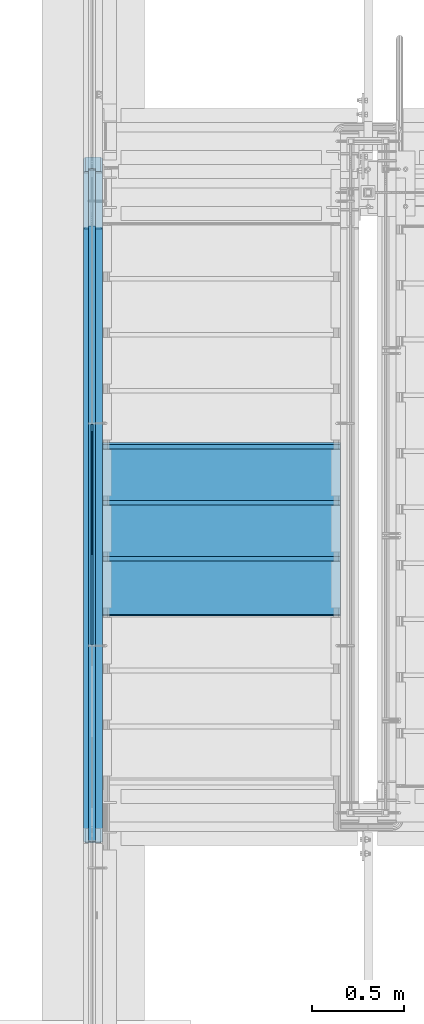
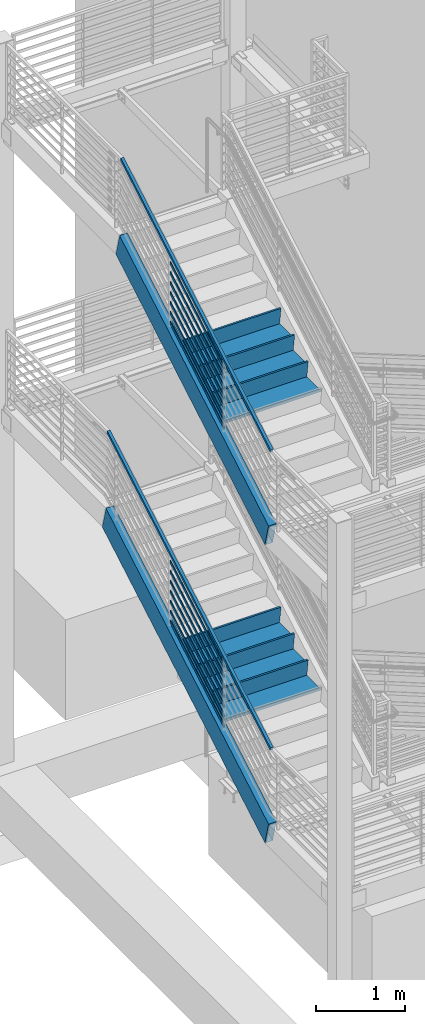
# One storey, part 754 of 1179: 18 members, 6 beams, 4 elements without a shape of their own.
"""IFC2X3 building model written with IfcOpenShell, lengths in millimetres."""

from ifc_helpers import new_model, si_unit, frame, origin_with_axes, place, context, subcontext, project, spatial, faceted_brep, material, type_object, element, aggregate, save


model = new_model("IFC2X3")

# Units and contexts
model_context = context("Model", 3, precision=1e-05, world=origin_with_axes())
body_context = subcontext(model_context, "Body", "Model", "MODEL_VIEW")
ifc_project = project(units=[si_unit("LENGTHUNIT", "METRE", prefix="MILLI"), si_unit("AREAUNIT", "SQUARE_METRE"), si_unit("VOLUMEUNIT", "CUBIC_METRE"), si_unit("MASSUNIT", "GRAM", prefix="KILO"), si_unit("TIMEUNIT", "SECOND"), si_unit("PLANEANGLEUNIT", "RADIAN"), si_unit("SOLIDANGLEUNIT", "STERADIAN"), si_unit("THERMODYNAMICTEMPERATUREUNIT", "DEGREE_CELSIUS"), si_unit("LUMINOUSINTENSITYUNIT", "LUMEN")], contexts=[model_context])

# Site, building, storey
site_placement = place(None, origin_with_axes())
site = spatial("IfcSite", under=ifc_project, at=site_placement, CompositionType="ELEMENT")
building_placement = place(site_placement, origin_with_axes())
building = spatial("IfcBuilding", under=site, at=building_placement, Name="Undefined", CompositionType="ELEMENT")
storey_placement = place(building_placement, origin_with_axes())
storey = spatial("IfcBuildingStorey", under=building, at=storey_placement, Name="Undefined", CompositionType="ELEMENT", Elevation=0.0)

# Assembly, members
assembly_1_placement = place(storey_placement, origin_with_axes())
assembly_1 = element("IfcElementAssembly", 1, at=assembly_1_placement, inside=storey, Name="GUARDRAIL", AssemblyPlace="NOTDEFINED", PredefinedType="RIGID_FRAME")
ifc_material_1 = material(Name="STEEL/A36")
member_type_1 = type_object("IfcMemberType", PredefinedType="NOTDEFINED")
member_1_placement = place(assembly_1_placement, frame((-3257.54999923555, 33867.7987430372, 7639.66614755741), z_axis=(0.0, -0.503871025834967, 0.863778900717086), x_axis=(0.0, -0.863778900717086, -0.503871025834967)))
member_1 = element("IfcMember", 2, at=member_1_placement, type_object=member_type_1, material=ifc_material_1, Name="PLATE", context=body_context, shape_type="Brep", body=[
    faceted_brep([(27.7385637234547, 4.76250000000005, -19.0500000000011), (5.51356370517169, 4.76250000000005, 19.0500000000338), (1396.15685487731, 4.76250000000005, 19.0500000012689), (1418.38185489559, 4.76250000000005, -19.049999998766), (5.51356370517169, -4.76250000000005, 19.0500000000338), (1396.15685487731, -4.76250000000005, 19.0500000012689), (27.7385637234547, -4.76250000000005, -19.0500000000011), (1418.38185489559, -4.76250000000005, -19.049999998766)], [[[0, 1, 2, 3]], [[1, 4, 5, 2]], [[4, 6, 7, 5]], [[6, 0, 3, 7]], [[5, 7, 3, 2]], [[6, 4, 1, 0]]]),
])
member_2_placement = place(assembly_1_placement, frame((-3257.54999923555, 33867.7987430373, 7775.83092631768), z_axis=(0.0, -0.503871025834967, 0.863778900717086), x_axis=(0.0, -0.863778900717086, -0.503871025834967)))
member_2 = element("IfcMember", 3, at=member_2_placement, type_object=member_type_1, material=ifc_material_1, Name="PLATE", context=body_context, shape_type="Brep", body=[
    faceted_brep([(27.7385637234547, 4.76250000000005, -19.0500000000011), (5.51356370517169, 4.76250000000005, 19.0500000000338), (1396.15685487731, 4.76250000000005, 19.0500000012689), (1418.38185489559, 4.76250000000005, -19.049999998766), (5.51356370517169, -4.76250000000005, 19.0500000000338), (1396.15685487731, -4.76250000000005, 19.0500000012689), (27.7385637234547, -4.76250000000005, -19.0500000000011), (1418.38185489559, -4.76250000000005, -19.049999998766)], [[[0, 1, 2, 3]], [[1, 4, 5, 2]], [[4, 6, 7, 5]], [[6, 0, 3, 7]], [[5, 7, 3, 2]], [[6, 4, 1, 0]]]),
])
member_3_placement = place(assembly_1_placement, frame((-3257.54999923555, 33867.7987430373, 7912.01384991899), z_axis=(0.0, -0.503871025834967, 0.863778900717086), x_axis=(0.0, -0.863778900717086, -0.503871025834967)))
member_3 = element("IfcMember", 4, at=member_3_placement, type_object=member_type_1, material=ifc_material_1, Name="PLATE", context=body_context, shape_type="Brep", body=[
    faceted_brep([(27.7385637234547, 4.76250000000005, -19.0500000000011), (5.51356370517169, 4.76250000000005, 19.0500000000338), (1396.15685487731, 4.76250000000005, 19.0500000012689), (1418.38185489559, 4.76250000000005, -19.049999998766), (5.51356370517169, -4.76250000000005, 19.0500000000338), (1396.15685487731, -4.76250000000005, 19.0500000012689), (27.7385637234547, -4.76250000000005, -19.0500000000011), (1418.38185489559, -4.76250000000005, -19.049999998766)], [[[0, 1, 2, 3]], [[1, 4, 5, 2]], [[4, 6, 7, 5]], [[6, 0, 3, 7]], [[5, 7, 3, 2]], [[6, 4, 1, 0]]]),
])
member_4_placement = place(assembly_1_placement, frame((-3257.54999923555, 33867.7987430373, 8048.19677352032), z_axis=(0.0, -0.503871025834967, 0.863778900717086), x_axis=(0.0, -0.863778900717086, -0.503871025834967)))
member_4 = element("IfcMember", 5, at=member_4_placement, type_object=member_type_1, material=ifc_material_1, Name="PLATE", context=body_context, shape_type="Brep", body=[
    faceted_brep([(27.7385637234547, 4.76250000000005, -19.0500000000011), (5.51356370517169, 4.76250000000005, 19.0500000000338), (1396.15685487731, 4.76250000000005, 19.0500000012689), (1418.38185489559, 4.76250000000005, -19.049999998766), (5.51356370517169, -4.76250000000005, 19.0500000000338), (1396.15685487731, -4.76250000000005, 19.0500000012689), (27.7385637234547, -4.76250000000005, -19.0500000000011), (1418.38185489559, -4.76250000000005, -19.049999998766)], [[[0, 1, 2, 3]], [[1, 4, 5, 2]], [[4, 6, 7, 5]], [[6, 0, 3, 7]], [[5, 7, 3, 2]], [[6, 4, 1, 0]]]),
])
member_5_placement = place(assembly_1_placement, frame((-3257.54999923555, 33867.7987430417, 8184.37969712425), z_axis=(0.0, -0.503871025834967, 0.863778900717086), x_axis=(0.0, -0.863778900717086, -0.503871025834967)))
member_5 = element("IfcMember", 6, at=member_5_placement, type_object=member_type_1, material=ifc_material_1, Name="PLATE", context=body_context, shape_type="Brep", body=[
    faceted_brep([(27.7385637234547, 4.76250000000005, -19.0500000000011), (5.51356370517169, 4.76250000000005, 19.0500000000338), (1396.15685487731, 4.76250000000005, 19.0500000012689), (1418.38185489559, 4.76250000000005, -19.049999998766), (5.51356370517169, -4.76250000000005, 19.0500000000338), (1396.15685487731, -4.76250000000005, 19.0500000012689), (27.7385637234547, -4.76250000000005, -19.0500000000011), (1418.38185489559, -4.76250000000005, -19.049999998766)], [[[0, 1, 2, 3]], [[1, 4, 5, 2]], [[4, 6, 7, 5]], [[6, 0, 3, 7]], [[5, 7, 3, 2]], [[6, 4, 1, 0]]]),
])
member_6_placement = place(assembly_1_placement, frame((-3257.54999923555, 33867.7987430361, 8320.56262072233), z_axis=(0.0, -0.503871025834967, 0.863778900717086), x_axis=(0.0, -0.863778900717086, -0.503871025834967)))
member_6 = element("IfcMember", 7, at=member_6_placement, type_object=member_type_1, material=ifc_material_1, Name="PLATE", context=body_context, shape_type="Brep", body=[
    faceted_brep([(27.7385637234547, 4.76250000000005, -19.0500000000011), (5.51356370517169, 4.76250000000005, 19.0500000000338), (1396.15685487731, 4.76250000000005, 19.0500000012689), (1418.38185489559, 4.76250000000005, -19.049999998766), (5.51356370517169, -4.76250000000005, 19.0500000000338), (1396.15685487731, -4.76250000000005, 19.0500000012689), (27.7385637234547, -4.76250000000005, -19.0500000000011), (1418.38185489559, -4.76250000000005, -19.049999998766)], [[[0, 1, 2, 3]], [[1, 4, 5, 2]], [[4, 6, 7, 5]], [[6, 0, 3, 7]], [[5, 7, 3, 2]], [[6, 4, 1, 0]]]),
])
member_7_placement = place(assembly_1_placement, frame((-3257.54999923555, 33867.7987430429, 8456.74554432763), z_axis=(0.0, -0.503871025834967, 0.863778900717086), x_axis=(0.0, -0.863778900717086, -0.503871025834967)))
member_7 = element("IfcMember", 8, at=member_7_placement, type_object=member_type_1, material=ifc_material_1, Name="PLATE", context=body_context, shape_type="Brep", body=[
    faceted_brep([(27.7385637234547, 4.76250000000005, -19.0500000000011), (5.51356370517169, 4.76250000000005, 19.0500000000338), (1396.15685487731, 4.76250000000005, 19.0500000012689), (1418.38185489559, 4.76250000000005, -19.049999998766), (5.51356370517169, -4.76250000000005, 19.0500000000338), (1396.15685487731, -4.76250000000005, 19.0500000012689), (27.7385637234547, -4.76250000000005, -19.0500000000011), (1418.38185489559, -4.76250000000005, -19.049999998766)], [[[0, 1, 2, 3]], [[1, 4, 5, 2]], [[4, 6, 7, 5]], [[6, 0, 3, 7]], [[5, 7, 3, 2]], [[6, 4, 1, 0]]]),
])

assembly_2_placement = place(storey_placement, origin_with_axes())
assembly_2 = element("IfcElementAssembly", 9, at=assembly_2_placement, inside=storey, Name="GUARDRAIL", AssemblyPlace="NOTDEFINED", PredefinedType="RIGID_FRAME")
member_8_placement = place(assembly_2_placement, frame((-3257.54999923555, 33867.745305077, 3556.74864643349), z_axis=(0.0, -0.501065882891537, 0.865409140812671), x_axis=(0.0, -0.86540914081267, -0.501065882891538)))
member_8 = element("IfcMember", 10, at=member_8_placement, type_object=member_type_1, material=ifc_material_1, Name="PLATE", context=body_context, shape_type="Brep", body=[
    faceted_brep([(27.5628128089447, 4.76250000000005, -19.0499999999756), (5.50317738577724, 4.76250000000005, 19.0499999999902), (1393.52680304928, 4.76249999999982, 19.0499999980784), (1415.58643847238, 4.76249999999982, -19.0500000019292), (5.50317738577724, -4.76250000000005, 19.0499999999902), (1393.52680304928, -4.76250000000027, 19.0499999980784), (27.5628128089447, -4.76250000000005, -19.0499999999756), (1415.58643847238, -4.76250000000027, -19.0500000019292)], [[[0, 1, 2, 3]], [[1, 4, 5, 2]], [[4, 6, 7, 5]], [[6, 0, 3, 7]], [[5, 7, 3, 2]], [[6, 4, 1, 0]]]),
])
member_9_placement = place(assembly_2_placement, frame((-3257.54999923555, 33867.745305077, 3692.849065398), z_axis=(0.0, -0.501065882891537, 0.865409140812671), x_axis=(0.0, -0.86540914081267, -0.501065882891538)))
member_9 = element("IfcMember", 11, at=member_9_placement, type_object=member_type_1, material=ifc_material_1, Name="PLATE", context=body_context, shape_type="Brep", body=[
    faceted_brep([(27.5628128089447, 4.76250000000005, -19.0499999999756), (5.50317738577724, 4.76250000000005, 19.0499999999902), (1393.52680304928, 4.76249999999982, 19.0499999980784), (1415.58643847238, 4.76249999999982, -19.0500000019292), (5.50317738577724, -4.76250000000005, 19.0499999999902), (1393.52680304928, -4.76250000000027, 19.0499999980784), (27.5628128089447, -4.76250000000005, -19.0499999999756), (1415.58643847238, -4.76250000000027, -19.0500000019292)], [[[0, 1, 2, 3]], [[1, 4, 5, 2]], [[4, 6, 7, 5]], [[6, 0, 3, 7]], [[5, 7, 3, 2]], [[6, 4, 1, 0]]]),
])
member_10_placement = place(assembly_2_placement, frame((-3257.54999923555, 33867.745305077, 3828.94948436251), z_axis=(0.0, -0.501065882891537, 0.865409140812671), x_axis=(0.0, -0.86540914081267, -0.501065882891538)))
member_10 = element("IfcMember", 12, at=member_10_placement, type_object=member_type_1, material=ifc_material_1, Name="PLATE", context=body_context, shape_type="Brep", body=[
    faceted_brep([(27.5628128089447, 4.76250000000005, -19.0499999999756), (5.50317738577724, 4.76250000000005, 19.0499999999902), (1393.52680304928, 4.76249999999982, 19.0499999980784), (1415.58643847238, 4.76249999999982, -19.0500000019292), (5.50317738577724, -4.76250000000005, 19.0499999999902), (1393.52680304928, -4.76250000000027, 19.0499999980784), (27.5628128089447, -4.76250000000005, -19.0499999999756), (1415.58643847238, -4.76250000000027, -19.0500000019292)], [[[0, 1, 2, 3]], [[1, 4, 5, 2]], [[4, 6, 7, 5]], [[6, 0, 3, 7]], [[5, 7, 3, 2]], [[6, 4, 1, 0]]]),
])
member_11_placement = place(assembly_2_placement, frame((-3257.54999923555, 33867.745305077, 3965.04990332702), z_axis=(0.0, -0.501065882891537, 0.865409140812671), x_axis=(0.0, -0.86540914081267, -0.501065882891538)))
member_11 = element("IfcMember", 13, at=member_11_placement, type_object=member_type_1, material=ifc_material_1, Name="PLATE", context=body_context, shape_type="Brep", body=[
    faceted_brep([(27.5628128089447, 4.76250000000005, -19.0499999999756), (5.50317738577724, 4.76250000000005, 19.0499999999902), (1393.52680304928, 4.76249999999982, 19.0499999980784), (1415.58643847238, 4.76249999999982, -19.0500000019292), (5.50317738577724, -4.76250000000005, 19.0499999999902), (1393.52680304928, -4.76250000000027, 19.0499999980784), (27.5628128089447, -4.76250000000005, -19.0499999999756), (1415.58643847238, -4.76250000000027, -19.0500000019292)], [[[0, 1, 2, 3]], [[1, 4, 5, 2]], [[4, 6, 7, 5]], [[6, 0, 3, 7]], [[5, 7, 3, 2]], [[6, 4, 1, 0]]]),
])
member_12_placement = place(assembly_2_placement, frame((-3257.54999923555, 33867.745305077, 4101.15032229153), z_axis=(0.0, -0.501065882891537, 0.865409140812671), x_axis=(0.0, -0.86540914081267, -0.501065882891538)))
member_12 = element("IfcMember", 14, at=member_12_placement, type_object=member_type_1, material=ifc_material_1, Name="PLATE", context=body_context, shape_type="Brep", body=[
    faceted_brep([(27.5628128089447, 4.76250000000005, -19.0499999999756), (5.50317738577724, 4.76250000000005, 19.0499999999902), (1393.52680304928, 4.76249999999982, 19.0499999980784), (1415.58643847238, 4.76249999999982, -19.0500000019292), (5.50317738577724, -4.76250000000005, 19.0499999999902), (1393.52680304928, -4.76250000000027, 19.0499999980784), (27.5628128089447, -4.76250000000005, -19.0499999999756), (1415.58643847238, -4.76250000000027, -19.0500000019292)], [[[0, 1, 2, 3]], [[1, 4, 5, 2]], [[4, 6, 7, 5]], [[6, 0, 3, 7]], [[5, 7, 3, 2]], [[6, 4, 1, 0]]]),
])
member_13_placement = place(assembly_2_placement, frame((-3257.54999923555, 33867.745305077, 4237.25074125604), z_axis=(0.0, -0.501065882891537, 0.865409140812671), x_axis=(0.0, -0.86540914081267, -0.501065882891538)))
member_13 = element("IfcMember", 15, at=member_13_placement, type_object=member_type_1, material=ifc_material_1, Name="PLATE", context=body_context, shape_type="Brep", body=[
    faceted_brep([(27.5628128089447, 4.76250000000005, -19.0499999999756), (5.50317738577724, 4.76250000000005, 19.0499999999902), (1393.52680304928, 4.76249999999982, 19.0499999980784), (1415.58643847238, 4.76249999999982, -19.0500000019292), (5.50317738577724, -4.76250000000005, 19.0499999999902), (1393.52680304928, -4.76250000000027, 19.0499999980784), (27.5628128089447, -4.76250000000005, -19.0499999999756), (1415.58643847238, -4.76250000000027, -19.0500000019292)], [[[0, 1, 2, 3]], [[1, 4, 5, 2]], [[4, 6, 7, 5]], [[6, 0, 3, 7]], [[5, 7, 3, 2]], [[6, 4, 1, 0]]]),
])
member_14_placement = place(assembly_2_placement, frame((-3257.54999923555, 33867.745305077, 4373.35116022054), z_axis=(0.0, -0.501065882891537, 0.865409140812671), x_axis=(0.0, -0.86540914081267, -0.501065882891538)))
member_14 = element("IfcMember", 16, at=member_14_placement, type_object=member_type_1, material=ifc_material_1, Name="PLATE", context=body_context, shape_type="Brep", body=[
    faceted_brep([(27.5628128089447, 4.76250000000005, -19.0499999999756), (5.50317738577724, 4.76250000000005, 19.0499999999902), (1393.52680304928, 4.76249999999982, 19.0499999980784), (1415.58643847238, 4.76249999999982, -19.0500000019292), (5.50317738577724, -4.76250000000005, 19.0499999999902), (1393.52680304928, -4.76250000000027, 19.0499999980784), (27.5628128089447, -4.76250000000005, -19.0499999999756), (1415.58643847238, -4.76250000000027, -19.0500000019292)], [[[0, 1, 2, 3]], [[1, 4, 5, 2]], [[4, 6, 7, 5]], [[6, 0, 3, 7]], [[5, 7, 3, 2]], [[6, 4, 1, 0]]]),
])

# Member
ifc_material_2 = material()
member_type_2 = type_object("IfcMemberType", Name="HSS1-1/2X1-1/2X1/4", PredefinedType="NOTDEFINED")
member_15_placement = place(assembly_1_placement, frame((-3257.54999923555, 34933.2514080909, 9211.25498805845), z_axis=(0.0, -0.50386730893911, 0.86378106889562), x_axis=(0.0, -0.863781068895619, -0.503867308939112)))
member_15 = element("IfcMember", 17, at=member_15_placement, type_object=member_type_2, material=ifc_material_2, Name="GUARDRAIL", ObjectType="HSS1-1/2X1-1/2X1/4", context=body_context, shape_type="Brep", body=[
    faceted_brep([(-1.61168691324565, 12.6999993300001, -12.6999993299905), (-1.61168691324565, -12.6999993300001, -12.6999993299905), (3879.86056470913, -12.6999993300001, -12.6999993268237), (3879.86056470913, 12.6999993300001, -12.6999993268237), (-8.47821297634073, -12.6999993300001, 12.6999993299833), (3872.99322680782, -12.6999993300001, 12.6999993331501), (-8.47821297634073, 12.6999993300001, 12.6999993299833), (3872.99322680782, 12.6999993300001, 12.6999993331501), (0.104944667415111, 19.0499992350001, -19.0499992349778), (-10.1948445569942, 19.0499992350001, 19.0499992349778), (3871.2763922676, 19.0499992350001, 19.0499992381428), (3881.57739924935, 19.0499992350001, -19.0499992318164), (-10.1948445569942, -19.0499992350001, 19.0499992349778), (3871.2763922676, -19.0499992350001, 19.0499992381428), (0.104944667415111, -19.0499992350001, -19.0499992349778), (3881.57739924935, -19.0499992350001, -19.0499992318164)], [[[0, 1, 2, 3]], [[1, 4, 5, 2]], [[4, 6, 7, 5]], [[6, 0, 3, 7]], [[8, 9, 10, 11]], [[9, 12, 13, 10]], [[12, 14, 15, 13]], [[14, 8, 11, 15]], [[13, 15, 11, 10], [5, 7, 3, 2]], [[14, 12, 9, 8], [6, 4, 1, 0]]]),
])

aggregate(assembly_1, [member_1, member_2, member_3, member_4, member_5, member_6, member_7, member_15])

member_16_placement = place(assembly_2_placement, frame((-3257.54999923555, 35238.0716986746, 5299.68604428136), z_axis=(0.0, -0.501065882891537, 0.865409140812671), x_axis=(0.0, -0.86540914081267, -0.501065882891538)))
member_16 = element("IfcMember", 18, at=member_16_placement, type_object=member_type_2, material=ifc_material_2, Name="GUARDRAIL", ObjectType="HSS1-1/2X1-1/2X1/4", context=body_context, shape_type="Brep", body=[
    faceted_brep([(-1.70558740210981, 12.6999993300001, -12.6999993299887), (-1.70558740210981, -12.6999993300001, -12.6999993299887), (4224.8400248205, -12.6999993300001, -12.6999993357858), (4224.8400248205, 12.6999993300001, -12.6999993357858), (-8.52793707742239, -12.6999993300001, 12.6999993300051), (4218.01682562654, -12.6999993300001, 12.699999324208), (-8.52793707742239, 12.6999993300001, 12.6999993300051), (4218.01682562654, 12.6999993300001, 12.699999324208), (0.0, 19.0499992350015, -19.0499992349996), (-10.2335245607173, 19.0499992350001, 19.0499992350015), (4216.31102576358, 19.0499992350001, 19.0499992292062), (4226.54582468346, 19.0499992350001, -19.049999240784), (-10.2335245607173, -19.0499992350001, 19.0499992350015), (4216.31102576358, -19.0499992350001, 19.0499992292062), (0.0, -19.0499992350015, -19.0499992349996), (4226.54582468346, -19.0499992350001, -19.049999240784)], [[[0, 1, 2, 3]], [[1, 4, 5, 2]], [[4, 6, 7, 5]], [[6, 0, 3, 7]], [[8, 9, 10, 11]], [[9, 12, 13, 10]], [[12, 14, 15, 13]], [[14, 8, 11, 15]], [[13, 15, 11, 10], [5, 7, 3, 2]], [[14, 12, 9, 8], [6, 4, 1, 0]]]),
])

aggregate(assembly_2, [member_8, member_9, member_10, member_11, member_12, member_13, member_14, member_16])

# Assembly, beams
assembly_3_placement = place(storey_placement, origin_with_axes())
assembly_3 = element("IfcElementAssembly", 19, at=assembly_3_placement, inside=storey, Name="STRINGER", AssemblyPlace="NOTDEFINED", PredefinedType="RIGID_FRAME")
beam_type_1 = type_object("IfcBeamType", PredefinedType="NOTDEFINED")
beam_1_placement = place(assembly_3_placement, frame((-2552.70000000063, 33743.9000004697, 3351.47708333393), z_axis=(1.0, 0.0, 0.0), x_axis=(0.0, -1.0, 0.0)))
beam_1 = element("IfcBeam", 20, at=beam_1_placement, type_object=beam_type_1, material=ifc_material_1, Name="TREAD", context=body_context, shape_type="Brep", body=[
    faceted_brep([(-5.47515810467303e-10, -1.58750000000146, -647.7), (-5.47515810467303e-10, -1.58750000000146, 647.7), (5.49334799870849e-10, 1.58749999999418, 647.7), (5.49334799870849e-10, 1.58749999999418, -647.7), (21.7353257776667, 1.58750000000009, 647.7), (21.7353257776667, 1.58750000000009, -647.7), (25.4000000001688, -1.58750000000009, -647.7), (25.4000000001688, -1.58750000000009, 647.7), (-10.9762326817727, 228.864583333333, 647.7), (-10.9762326817727, 228.864583333333, -647.7), (-7.31154422789405, 225.689583333333, -647.7), (-7.31154422789405, 225.689583333333, 647.7), (319.223767229007, 228.864583333333, 647.7), (319.223767229007, 228.864583333333, -647.7), (316.473021803613, 225.689583333333, -647.7), (316.473021803613, 225.689583333333, 647.7), (325.043366447484, 188.430492929979, 647.7), (325.043366447484, 188.430492929979, -647.7), (321.900749692417, 187.978182272578, 647.7), (321.900749692417, 187.978182272578, -647.7)], [[[0, 1, 2, 3]], [[3, 2, 4, 5]], [[1, 0, 6, 7]], [[5, 4, 8, 9]], [[7, 6, 10, 11]], [[9, 8, 12, 13]], [[11, 10, 14, 15]], [[13, 12, 16, 17]], [[12, 8, 4, 2, 1, 7, 11, 15, 18, 16]], [[15, 14, 19, 18]], [[14, 10, 6, 0, 3, 5, 9, 13, 17, 19]], [[18, 19, 17, 16]]]),
])
beam_2_placement = place(assembly_3_placement, frame((-2552.70000000067, 33439.100000559, 3175.00000000059), z_axis=(1.0, 0.0, 0.0), x_axis=(0.0, -1.0, 0.0)))
beam_2 = element("IfcBeam", 21, at=beam_2_placement, type_object=beam_type_1, material=ifc_material_1, Name="TREAD", context=body_context, shape_type="Brep", body=[
    faceted_brep([(-5.47515810467303e-10, -1.58750000000146, -647.7), (-5.47515810467303e-10, -1.58750000000146, 647.7), (5.49334799870849e-10, 1.58749999999418, 647.7), (5.49334799870849e-10, 1.58749999999418, -647.7), (21.7353257776667, 1.58750000000009, 647.7), (21.7353257776667, 1.58750000000009, -647.7), (25.4000000001688, -1.58750000000009, -647.7), (25.4000000001688, -1.58750000000009, 647.7), (-10.9762326817727, 228.864583333333, 647.7), (-10.9762326817727, 228.864583333333, -647.7), (-7.31154422789405, 225.689583333333, -647.7), (-7.31154422789405, 225.689583333333, 647.7), (319.223767229007, 228.864583333333, 647.7), (319.223767229007, 228.864583333333, -647.7), (316.473021803613, 225.689583333333, -647.7), (316.473021803613, 225.689583333333, 647.7), (325.043366447484, 188.430492929979, 647.7), (325.043366447484, 188.430492929979, -647.7), (321.900749692417, 187.978182272578, 647.7), (321.900749692417, 187.978182272578, -647.7)], [[[0, 1, 2, 3]], [[3, 2, 4, 5]], [[1, 0, 6, 7]], [[5, 4, 8, 9]], [[7, 6, 10, 11]], [[9, 8, 12, 13]], [[11, 10, 14, 15]], [[13, 12, 16, 17]], [[12, 8, 4, 2, 1, 7, 11, 15, 18, 16]], [[15, 14, 19, 18]], [[14, 10, 6, 0, 3, 5, 9, 13, 17, 19]], [[18, 19, 17, 16]]]),
])
beam_3_placement = place(assembly_3_placement, frame((-2552.70000000071, 33134.3000006482, 2998.52291666726), z_axis=(1.0, 0.0, 0.0), x_axis=(0.0, -1.0, 0.0)))
beam_3 = element("IfcBeam", 22, at=beam_3_placement, type_object=beam_type_1, material=ifc_material_1, Name="TREAD", context=body_context, shape_type="Brep", body=[
    faceted_brep([(-5.47515810467303e-10, -1.58750000000146, -647.7), (-5.47515810467303e-10, -1.58750000000146, 647.7), (5.49334799870849e-10, 1.58749999999418, 647.7), (5.49334799870849e-10, 1.58749999999418, -647.7), (21.7353257776667, 1.58750000000009, 647.7), (21.7353257776667, 1.58750000000009, -647.7), (25.4000000001688, -1.58750000000009, -647.7), (25.4000000001688, -1.58750000000009, 647.7), (-10.9762326817727, 228.864583333333, 647.7), (-10.9762326817727, 228.864583333333, -647.7), (-7.31154422789405, 225.689583333333, -647.7), (-7.31154422789405, 225.689583333333, 647.7), (319.223767229007, 228.864583333333, 647.7), (319.223767229007, 228.864583333333, -647.7), (316.473021803613, 225.689583333333, -647.7), (316.473021803613, 225.689583333333, 647.7), (325.043366447484, 188.430492929979, 647.7), (325.043366447484, 188.430492929979, -647.7), (321.900749692417, 187.978182272578, 647.7), (321.900749692417, 187.978182272578, -647.7)], [[[0, 1, 2, 3]], [[3, 2, 4, 5]], [[1, 0, 6, 7]], [[5, 4, 8, 9]], [[7, 6, 10, 11]], [[9, 8, 12, 13]], [[11, 10, 14, 15]], [[13, 12, 16, 17]], [[12, 8, 4, 2, 1, 7, 11, 15, 18, 16]], [[15, 14, 19, 18]], [[14, 10, 6, 0, 3, 5, 9, 13, 17, 19]], [[18, 19, 17, 16]]]),
])

# Assembly, member
assembly_4_placement = place(storey_placement, origin_with_axes())
assembly_4 = element("IfcElementAssembly", 23, at=assembly_4_placement, inside=storey, Name="STRINGER", AssemblyPlace="NOTDEFINED", PredefinedType="RIGID_FRAME")
member_type_3 = type_object("IfcMemberType", Name="HSS12X4X3/8", PredefinedType="NOTDEFINED")
member_17_placement = place(assembly_4_placement, frame((-3251.19999997223, 35000.7562079377, 8066.21009551441), z_axis=(0.0, -0.503871025834967, 0.863778900717086), x_axis=(0.0, -0.863778900717086, -0.503871025834967)))
member_17 = element("IfcMember", 24, at=member_17_placement, type_object=member_type_3, material=ifc_material_2, Name="STRINGER", ObjectType="HSS12X4X3/8", context=body_context, shape_type="Brep", body=[
    faceted_brep([(3961.46543237346, -41.2750000000001, -143.20509636464), (3954.42626667955, -50.4699036320367, -152.399999996698), (3954.42626667955, 50.4699036320367, -152.399999996698), (3961.46543237346, 41.2750000000001, -143.20509636464), (3884.03468255634, -41.2750000000001, 143.205096371612), (3872.0238482502, -50.4699036320367, 152.400000003649), (3871.68190144677, -50.8000000000002, 152.400000003652), (3954.08431987612, -50.8000000000002, -152.399999996698), (3884.03468255634, 41.2750000000001, 143.205096371612), (3872.0238482502, 50.4699036320367, 152.400000003649), (3954.08431987612, 50.8000000000002, -152.399999996698), (3871.68190144677, 50.8000000000002, 152.400000003652), (92.2693648904242, -50.8000000000029, -152.399999996655), (9.86694677204105, -50.8000000000029, 152.400000000649), (9.52499998274288, -50.4699036320367, 152.400000000223), (2.4858342888474, -41.2750000000001, 143.205096368167), (79.916584105973, -41.2750000000001, -143.205096368083), (91.927418412095, -50.4699036320367, -152.400000000127), (79.916584105973, 41.2750000000001, -143.205096368083), (91.927418412095, 50.4699036320367, -152.400000000127), (9.52499998274288, 50.4699036320367, 152.400000000223), (2.4858342888474, 41.2750000000001, 143.205096368167), (9.86694677204468, 50.8000000000029, 152.39999999994), (92.2693648904242, 50.8000000000029, -152.399999999852), (79.827342666882, 41.2750000000015, -142.875), (79.827342666882, -41.2750000000015, -142.875), (3961.37619110366, -41.2750000000001, -142.87499999668), (3961.37619110366, 41.2750000000001, -142.87499999668), (2.57507555327538, -41.2750000000015, 142.875), (3884.12392382614, -41.2750000000001, 142.875000003649), (2.57507555327538, 41.2750000000015, 142.875), (3884.12392382614, 41.2750000000001, 142.875000003649)], [[[0, 1, 2, 3]], [[4, 5, 6, 7, 1, 0]], [[8, 9, 5, 4]], [[10, 11, 9, 8, 3, 2]], [[12, 13, 14, 15, 16, 17]], [[18, 19, 17, 16]], [[20, 21, 15, 14]], [[21, 20, 22, 23, 19, 18]], [[24, 25, 26, 27]], [[25, 28, 29, 26]], [[28, 30, 31, 29]], [[30, 24, 27, 31]], [[23, 22, 11, 10]], [[9, 11, 22, 20, 14, 13, 6, 5]], [[13, 12, 7, 6]], [[7, 12, 17, 19, 23, 10, 2, 1]], [[8, 4, 0, 3], [29, 31, 27, 26]], [[21, 18, 16, 15], [30, 28, 25, 24]]]),
])

# Member
member_18_placement = place(assembly_3_placement, frame((-3251.20000000861, 35305.2170979194, 4154.36164692825), z_axis=(0.0, -0.501065882891537, 0.865409140812671), x_axis=(0.0, -0.86540914081267, -0.501065882891538)))
member_18 = element("IfcMember", 25, at=member_18_placement, type_object=member_type_3, material=ifc_material_2, Name="STRINGER", ObjectType="HSS12X4X3/8", context=body_context, shape_type="Brep", body=[
    faceted_brep([(91.7346902094068, -50.8000000000006, -152.400000000034), (9.86264972250137, -50.8, 152.400000000118), (9.52500001294902, -50.4739097931884, 152.400000000122), (2.47091476370406, -41.2750000000005, 143.201075874518), (79.4011410688981, -41.2750000000005, -143.201075874638), (91.3970558661567, -50.4739241253851, -152.400000000032), (79.4011410688981, 41.2749999999996, -143.201075874638), (91.3970558661567, 50.4739241253842, -152.400000000032), (9.52500001294902, 50.4739097931884, 152.400000000122), (2.47091476370406, 41.2749999999996, 143.201075874518), (9.86264972250137, 50.8, 152.400000000118), (91.7346902094068, 50.7999999999997, -152.400000000034), (4305.84136011638, -41.2750000000005, -143.201075878047), (4228.91113410902, -41.2750000000005, 143.201075866336), (4216.91521932065, -50.4739241277712, 152.399999994117), (4216.57758497996, -50.8000000000006, 152.399999994119), (4298.44964056411, -50.8000000000006, -152.4000000058), (4298.78727490481, -50.4739241277707, -152.400000005802), (4298.78727490481, 50.4739241277707, -152.400000005802), (4305.84136011638, 41.2750000000001, -143.201075878047), (4228.91113410902, 41.2750000000001, 143.201075866336), (4216.91521932065, 50.4739241277712, 152.399999994117), (4298.44964056411, 50.7999999999997, -152.4000000058), (4216.57758497996, 50.7999999999997, 152.399999994119), (79.3135518111412, 41.2750000000015, -142.875), (79.3135518111412, -41.2750000000015, -142.875), (4305.75377316778, -41.2750000000005, -142.875000005819), (4305.75377316778, 41.2749999999996, -142.875000005819), (2.55849975384263, -41.2750000000015, 142.875), (4228.99872105763, -41.2750000000005, 142.874999994108), (2.55849975384263, 41.2750000000015, 142.875), (4228.99872105763, 41.2749999999996, 142.874999994108)], [[[0, 1, 2, 3, 4, 5]], [[6, 7, 5, 4]], [[8, 9, 3, 2]], [[9, 8, 10, 11, 7, 6]], [[12, 13, 14, 15, 16, 17]], [[18, 19, 12, 17]], [[20, 21, 14, 13]], [[22, 23, 21, 20, 19, 18]], [[24, 25, 26, 27]], [[25, 28, 29, 26]], [[28, 30, 31, 29]], [[30, 24, 27, 31]], [[23, 22, 11, 10]], [[15, 14, 21, 23, 10, 8, 2, 1]], [[16, 15, 1, 0]], [[7, 11, 22, 18, 17, 16, 0, 5]], [[19, 20, 13, 12], [29, 31, 27, 26]], [[9, 6, 4, 3], [30, 28, 25, 24]]]),
])

aggregate(assembly_3, [member_18, beam_1, beam_2, beam_3])

# Beam
beam_type_2 = type_object("IfcBeamType", PredefinedType="NOTDEFINED")
beam_4_placement = place(assembly_4_placement, frame((-2552.69999999813, 33743.9000009947, 7434.26249999919), z_axis=(1.0, 0.0, 0.0), x_axis=(0.0, -1.0, 0.0)))
beam_4 = element("IfcBeam", 26, at=beam_4_placement, type_object=beam_type_2, material=ifc_material_1, Name="TREAD", context=body_context, shape_type="Brep", body=[
    faceted_brep([(-5.47515810467303e-10, -1.58750000000146, -647.7), (-5.47515810467303e-10, -1.58750000000146, 647.7), (5.49334799870849e-10, 1.58749999999418, 647.7), (5.49334799870849e-10, 1.58749999999418, -647.7), (21.7391942417962, 1.58749999999964, 647.7), (21.7391942417962, 1.58749999999964, -647.7), (25.4000000001688, -1.58750000000009, -647.7), (25.4000000001688, -1.58750000000009, 647.7), (-10.9179486153444, 230.1875, 647.7), (-10.9179486153444, 230.1875, -647.7), (-7.25714285782306, 227.012500000001, -647.7), (-7.25714285782306, 227.012500000001, 647.7), (319.2820511338, 230.1875, 647.7), (319.2820511338, 230.1875, -647.7), (316.528388233419, 227.012500000001, -647.7), (316.528388233419, 227.012500000001, 647.7), (325.059631548502, 189.744437097058, 647.7), (325.059631548502, 189.744437097058, -647.7), (321.916541906132, 189.295424291005, 647.7), (321.916541906132, 189.295424291005, -647.7)], [[[0, 1, 2, 3]], [[3, 2, 4, 5]], [[1, 0, 6, 7]], [[5, 4, 8, 9]], [[7, 6, 10, 11]], [[9, 8, 12, 13]], [[11, 10, 14, 15]], [[13, 12, 16, 17]], [[12, 8, 4, 2, 1, 7, 11, 15, 18, 16]], [[15, 14, 19, 18]], [[14, 10, 6, 0, 3, 5, 9, 13, 17, 19]], [[18, 19, 17, 16]]]),
])

beam_5_placement = place(assembly_4_placement, frame((-2552.69999999792, 33439.1000012467, 7256.46249999919), z_axis=(1.0, 0.0, 0.0), x_axis=(0.0, -1.0, 0.0)))
beam_5 = element("IfcBeam", 27, at=beam_5_placement, type_object=beam_type_2, material=ifc_material_1, Name="TREAD", context=body_context, shape_type="Brep", body=[
    faceted_brep([(-5.47515810467303e-10, -1.58750000000146, -647.7), (-5.47515810467303e-10, -1.58750000000146, 647.7), (5.49334799870849e-10, 1.58749999999418, 647.7), (5.49334799870849e-10, 1.58749999999418, -647.7), (21.7391942417962, 1.58749999999964, 647.7), (21.7391942417962, 1.58749999999964, -647.7), (25.4000000001688, -1.58750000000009, -647.7), (25.4000000001688, -1.58750000000009, 647.7), (-10.9179486153444, 230.1875, 647.7), (-10.9179486153444, 230.1875, -647.7), (-7.25714285782306, 227.012500000001, -647.7), (-7.25714285782306, 227.012500000001, 647.7), (319.2820511338, 230.1875, 647.7), (319.2820511338, 230.1875, -647.7), (316.528388233419, 227.012500000001, -647.7), (316.528388233419, 227.012500000001, 647.7), (325.059631548502, 189.744437097058, 647.7), (325.059631548502, 189.744437097058, -647.7), (321.916541906132, 189.295424291005, 647.7), (321.916541906132, 189.295424291005, -647.7)], [[[0, 1, 2, 3]], [[3, 2, 4, 5]], [[1, 0, 6, 7]], [[5, 4, 8, 9]], [[7, 6, 10, 11]], [[9, 8, 12, 13]], [[11, 10, 14, 15]], [[13, 12, 16, 17]], [[12, 8, 4, 2, 1, 7, 11, 15, 18, 16]], [[15, 14, 19, 18]], [[14, 10, 6, 0, 3, 5, 9, 13, 17, 19]], [[18, 19, 17, 16]]]),
])

beam_6_placement = place(assembly_4_placement, frame((-2552.69999999772, 33134.3000014988, 7078.66249999919), z_axis=(1.0, 0.0, 0.0), x_axis=(0.0, -1.0, 0.0)))
beam_6 = element("IfcBeam", 28, at=beam_6_placement, type_object=beam_type_2, material=ifc_material_1, Name="TREAD", context=body_context, shape_type="Brep", body=[
    faceted_brep([(-5.47515810467303e-10, -1.58750000000146, -647.7), (-5.47515810467303e-10, -1.58750000000146, 647.7), (5.49334799870849e-10, 1.58749999999418, 647.7), (5.49334799870849e-10, 1.58749999999418, -647.7), (21.7391942417962, 1.58749999999964, 647.7), (21.7391942417962, 1.58749999999964, -647.7), (25.4000000001688, -1.58750000000009, -647.7), (25.4000000001688, -1.58750000000009, 647.7), (-10.9179486153444, 230.1875, 647.7), (-10.9179486153444, 230.1875, -647.7), (-7.25714285782306, 227.012500000001, -647.7), (-7.25714285782306, 227.012500000001, 647.7), (319.2820511338, 230.1875, 647.7), (319.2820511338, 230.1875, -647.7), (316.528388233419, 227.012500000001, -647.7), (316.528388233419, 227.012500000001, 647.7), (325.059631548502, 189.744437097058, 647.7), (325.059631548502, 189.744437097058, -647.7), (321.916541906132, 189.295424291005, 647.7), (321.916541906132, 189.295424291005, -647.7)], [[[0, 1, 2, 3]], [[3, 2, 4, 5]], [[1, 0, 6, 7]], [[5, 4, 8, 9]], [[7, 6, 10, 11]], [[9, 8, 12, 13]], [[11, 10, 14, 15]], [[13, 12, 16, 17]], [[12, 8, 4, 2, 1, 7, 11, 15, 18, 16]], [[15, 14, 19, 18]], [[14, 10, 6, 0, 3, 5, 9, 13, 17, 19]], [[18, 19, 17, 16]]]),
])

aggregate(assembly_4, [member_17, beam_4, beam_5, beam_6])

save(model, "model.ifc")
